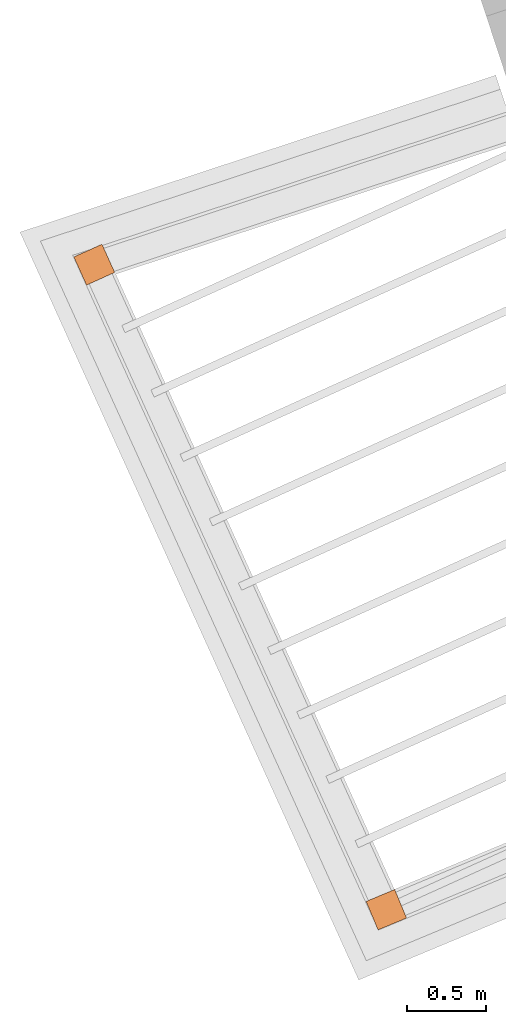
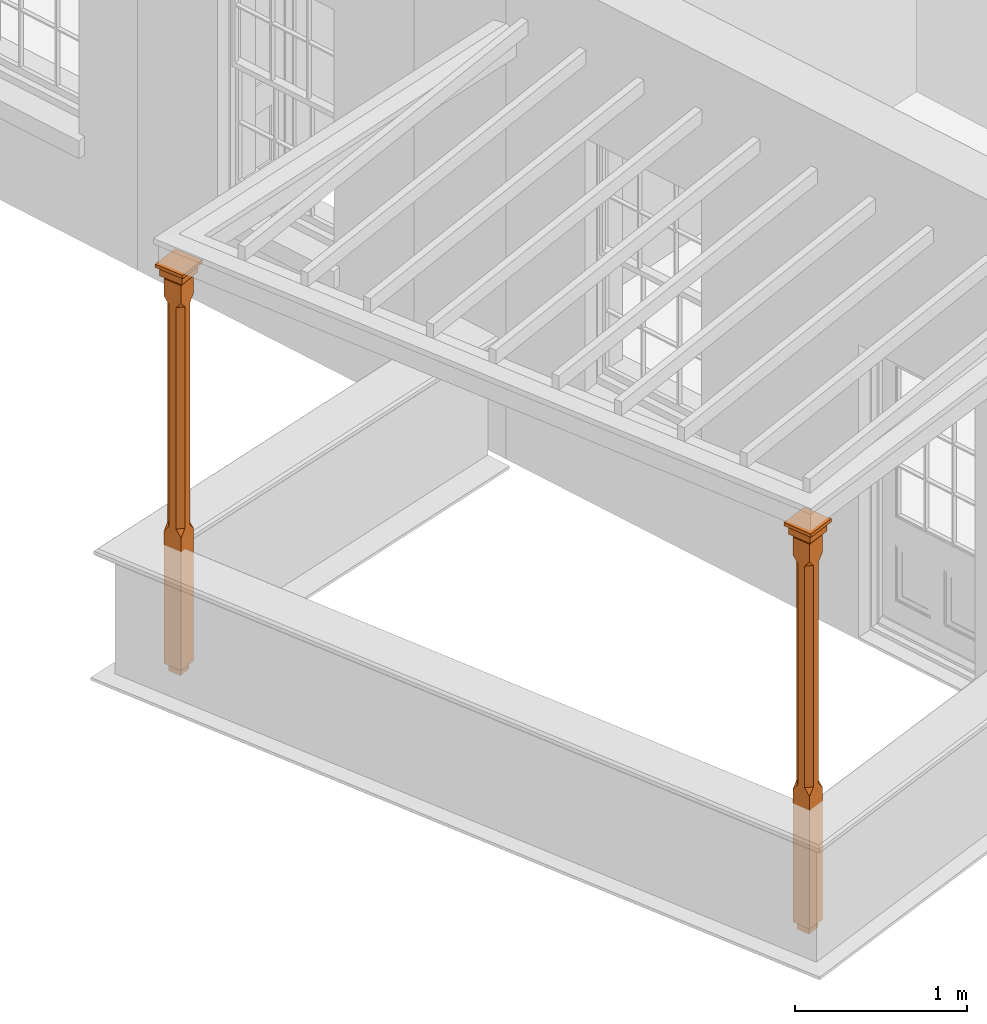
# One storey, part 10 of 10: 2 proxies.
"""IFC2X3 building model written with IfcOpenShell, lengths in metres."""

import ifcopenshell
import ifcopenshell.guid

model = None  # the IFC model being written
_history = None  # IfcOwnerHistory: only IFC2X3 demands one
_inside = {}  # id of a spatial element -> (the spatial element, [elements in it])
_under = {}  # id of a project, library or spatial element -> (it, [spatial elements below it])
_declared = {}  # id of a project -> (the project, [libraries it declares])
_typed = {}  # id of a type object -> (the type object, [elements of that type])
_made_of = {}  # id of a material, layer set ... -> (it, [elements and type objects made of it])


def new_model(schema):
    """Start an empty IFC model of exactly this schema.

    Asked for "IFC4X3", IfcOpenShell would pick the latest addendum, in which some entities
    have other attributes; the version numbers below select the first issue.
    IFC2X3 requires an IfcOwnerHistory on every rooted entity: one is made here for all.
    """
    global model, _history
    if schema == "IFC4X3":
        model = ifcopenshell.file(schema_version=(4, 3, 0, 0))
    else:
        model = ifcopenshell.file(schema=schema)
    _inside.clear()
    _under.clear()
    _declared.clear()
    _typed.clear()
    _made_of.clear()
    _history = None
    if model.schema == "IFC2X3":
        org = make("IfcOrganization", Name="unknown")
        user = make(
            "IfcPersonAndOrganization",
            ThePerson=make("IfcPerson", FamilyName="unknown"),
            TheOrganization=org,
        )
        app = make(
            "IfcApplication",
            ApplicationDeveloper=org,
            Version="unknown",
            ApplicationFullName="unknown",
            ApplicationIdentifier="unknown",
        )
        _history = make(
            "IfcOwnerHistory",
            OwningUser=user,
            OwningApplication=app,
            ChangeAction="ADDED",
            CreationDate=0,
        )
    return model


def make(cls, **values):
    """One entity of the class cls with the attributes given. An attribute that is None is left unset."""
    return model.create_entity(
        cls, **{name: value for name, value in values.items() if value is not None}
    )


def rooted(cls, **values):
    """An entity with a GlobalId (a new one), such as an element, a storey or a relation."""
    return make(cls, GlobalId=ifcopenshell.guid.new(), OwnerHistory=_history, **values)


def si_unit(unit_type, name, prefix=None):
    """IfcSIUnit, for example si_unit("LENGTHUNIT", "METRE", prefix="MILLI")."""
    return make("IfcSIUnit", UnitType=unit_type, Prefix=prefix, Name=name)


def assignment(units):
    """IfcUnitAssignment: the units of a project."""
    return None if units is None else make("IfcUnitAssignment", Units=units)


def point(xyz):
    """IfcCartesianPoint."""
    return None if xyz is None else make("IfcCartesianPoint", Coordinates=xyz)


def direction(xyz):
    """IfcDirection."""
    return None if xyz is None else make("IfcDirection", DirectionRatios=xyz)


def frame(location, z_axis=None, x_axis=None):
    """IfcAxis2Placement3D, a coordinate frame: its origin and axes. An axis left out is left unset."""
    return make(
        "IfcAxis2Placement3D",
        Location=point(location),
        Axis=direction(z_axis),
        RefDirection=direction(x_axis),
    )


def origin():
    """The frame at (0, 0, 0) with its axes left unset."""
    return frame((0.0, 0.0, 0.0))


def place(relative_to, where):
    """IfcLocalPlacement: puts the frame where relative to a parent placement (None: the world)."""
    return make(
        "IfcLocalPlacement", PlacementRelTo=relative_to, RelativePlacement=where
    )


def context(
    kind, dimensions, precision=None, world=None, true_north=None, identifier=None
):
    """IfcGeometricRepresentationContext, for example the 3D "Model" context."""
    return make(
        "IfcGeometricRepresentationContext",
        ContextIdentifier=identifier,
        ContextType=kind,
        CoordinateSpaceDimension=dimensions,
        Precision=precision,
        WorldCoordinateSystem=world,
        TrueNorth=true_north,
    )


def subcontext(parent, identifier, kind, view, scale=None):
    """IfcGeometricRepresentationSubContext, for example "Body" below "Model"."""
    return make(
        "IfcGeometricRepresentationSubContext",
        ContextIdentifier=identifier,
        ContextType=kind,
        ParentContext=parent,
        TargetScale=scale,
        TargetView=view,
    )


def project(units=None, contexts=None):
    """IfcProject with its units and contexts."""
    return rooted(
        "IfcProject",
        Name="project",
        RepresentationContexts=contexts,
        UnitsInContext=assignment(units),
    )


def spatial(cls, under=None, at=None, **own):
    """A site, building, storey or space (cls), placed at a placement, below another one or the project."""
    s = rooted(cls, ObjectPlacement=at, **own)
    if under is not None:
        _under.setdefault(under.id(), (under, []))[1].append(s)
    return s


def faces_of(points, faces, orient=None, outer=None):
    """IfcFace entities. A face is a list of loops; a loop is a list of indices into points, from 0.

    orient and outer hold one flag for each loop. By default every Orientation is true, the
    first loop of a face is its IfcFaceOuterBound and the others are IfcFaceBound.
    """
    made = []
    for i, loops in enumerate(faces):
        bounds = []
        for j, loop in enumerate(loops):
            is_outer = j == 0 if outer is None else outer[i][j]
            bounds.append(
                make(
                    "IfcFaceOuterBound" if is_outer else "IfcFaceBound",
                    Bound=make("IfcPolyLoop", Polygon=[points[k] for k in loop]),
                    Orientation=True if orient is None else orient[i][j],
                )
            )
        made.append(make("IfcFace", Bounds=bounds))
    return made


def faceted_brep(points, faces, orient=None, outer=None, voids=None):
    """IfcFacetedBrep: a solid bounded by flat faces; with voids (closed shells), ...WithVoids."""
    shared = [point(p) for p in points]
    hull = make("IfcClosedShell", CfsFaces=faces_of(shared, faces, orient, outer))
    if voids is None:
        return make("IfcFacetedBrep", Outer=hull)
    return make(
        "IfcFacetedBrepWithVoids",
        Outer=hull,
        Voids=[
            make(cls, CfsFaces=faces_of(shared, fs, o, b)) for cls, fs, o, b in voids
        ],
    )


def shape(context_of_items, identifier, shape_type, items):
    """IfcShapeRepresentation: the items that make up one representation, for example the "Body"."""
    return make(
        "IfcShapeRepresentation",
        ContextOfItems=context_of_items,
        RepresentationIdentifier=identifier,
        RepresentationType=shape_type,
        Items=items,
    )


def made_of(thing, what):
    """Note that an element or type object is made of a material, layer set ...; save() writes the relation."""
    if what is not None:
        _made_of.setdefault(what.id(), (what, []))[1].append(thing)
    return thing


def element(
    cls,
    number,
    at=None,
    inside=None,
    cuts=None,
    type_object=None,
    material=None,
    context=None,
    identifier="Body",
    shape_type=None,
    held_by="IfcProductDefinitionShape",
    body=None,
    shapes=None,
    **own,
):
    """One element of the class cls, such as IfcWall. Its Tag is "e" and its number.

    at: its placement. inside: the storey or other place that contains it. cuts: it is an
    opening in that element (IfcRelVoidsElement). A single representation is given by context,
    identifier, shape_type and body (its items); several are given by shapes. held_by: the class
    of the entity that holds the representations. save() writes the other relations.
    """
    e = rooted(cls, Tag="e%d" % number, ObjectPlacement=at, **own)
    if body is not None:
        shapes = [shape(context, identifier, shape_type, body)]
    if shapes is not None:
        e.Representation = make(held_by, Representations=shapes)
    if inside is not None:
        _inside.setdefault(inside.id(), (inside, []))[1].append(e)
    if cuts is not None:
        rooted(
            "IfcRelVoidsElement", RelatingBuildingElement=cuts, RelatedOpeningElement=e
        )
    if type_object is not None:
        _typed.setdefault(type_object.id(), (type_object, []))[1].append(e)
    return made_of(e, material)


def aggregate(whole, parts):
    """IfcRelAggregates: a whole, such as a stair, and the parts it consists of."""
    return rooted("IfcRelAggregates", RelatingObject=whole, RelatedObjects=parts)


def save(model, path):
    """Write the relations noted so far, then the file.

    IfcRelAggregates (storeys below a building ...), IfcRelContainedInSpatialStructure (elements
    in a storey), IfcRelDefinesByType, IfcRelAssociatesMaterial and IfcRelDeclares: one each for
    every whole, place, type object, material and project.
    """
    for whole, parts in _under.values():
        aggregate(whole, parts)
    for where, things in _inside.values():
        rooted(
            "IfcRelContainedInSpatialStructure",
            RelatedElements=things,
            RelatingStructure=where,
        )
    for kind, things in _typed.values():
        rooted("IfcRelDefinesByType", RelatedObjects=things, RelatingType=kind)
    for what, things in _made_of.values():
        rooted("IfcRelAssociatesMaterial", RelatedObjects=things, RelatingMaterial=what)
    for by, libraries in _declared.values():
        rooted("IfcRelDeclares", RelatingContext=by, RelatedDefinitions=libraries)
    model.write(path)


model = new_model("IFC2X3")

# Units and contexts
model_context = context("Model", 3, world=origin())
body_context = subcontext(model_context, "Body", "Model", "MODEL_VIEW")
ifc_project = project(units=[si_unit("PLANEANGLEUNIT", "RADIAN"), si_unit("MASSUNIT", "GRAM", prefix="KILO"), si_unit("FORCEUNIT", "NEWTON", prefix="KILO"), si_unit("LENGTHUNIT", "METRE")], contexts=[model_context])

# Site, building, storey
site_placement = place(None, origin())
site = spatial("IfcSite", under=ifc_project, at=site_placement, CompositionType="ELEMENT")
building_placement = place(None, origin())
building = spatial("IfcBuilding", under=site, at=building_placement, Name="Building plot-2", CompositionType="ELEMENT")
storey_placement = place(None, frame((0.0, 0.0, 4.6)))
storey = spatial("IfcBuildingStorey", under=building, at=storey_placement, Name="Floor 1", CompositionType="ELEMENT", Elevation=4.6)

# Proxies
proxy_1_placement = place(storey_placement, frame((26.6320151404297, 29.6644036171361, 0.0), z_axis=(0.0, 0.0, 1.0), x_axis=(0.412540918322107, -0.910939070799992, 0.0)))
element("IfcBuildingElementProxy", 1, at=proxy_1_placement, inside=storey, Name="pergola post", CompositionType="ELEMENT", context=body_context, shape_type="Brep", held_by="IfcProductRepresentation", body=[
    faceted_brep([(0.0246, -0.0615, 2.62), (0.0615, -0.0246, 2.62), (0.0615, -0.0615, 2.666667), (0.0615, -0.0246, 1.044444), (0.0246, -0.0615, 1.044444), (0.0615, 0.0246, 2.62), (0.0615, 0.0615, 2.666667), (-0.0246, -0.0615, 2.62), (-0.0615, -0.0615, 2.666667), (-0.0246, -0.0615, 1.044444), (0.0615, -0.0615, 0.997778), (0.0615, 0.0246, 1.044444), (0.0246, 0.0615, 2.62), (0.0615, 0.0615, 2.791111), (0.0615, -0.0615, 2.791111), (-0.0615, -0.0615, 2.791111), (-0.0615, -0.0246, 2.62), (-0.0615, -0.0246, 1.044444), (-0.0615, -0.0615, 0.997778), (0.0615, 0.0615, 0.997778), (0.0246, 0.0615, 1.044444), (-0.0246, 0.0615, 2.62), (-0.0615, 0.0615, 2.666667), (0.04305, 0.04305, 2.791111), (0.04305, -0.04305, 2.791111), (-0.0615, 0.0615, 2.791111), (-0.04305, -0.04305, 2.791111), (-0.0615, 0.0246, 2.62), (-0.0615, 0.0246, 1.044444), (0.0615, -0.0615, 0.053333), (-0.0615, -0.0615, 0.053333), (0.0615, 0.0615, 0.053333), (-0.0246, 0.0615, 1.044444), (-0.04305, 0.04305, 2.791111), (0.04305, 0.04305, 2.814444), (0.04305, -0.04305, 2.814444), (-0.04305, -0.04305, 2.814444), (-0.0615, 0.0615, 0.997778), (-0.0615, 0.0615, 0.053333), (-0.04305, -0.04305, 0.053333), (0.04305, -0.04305, 0.053333), (0.04305, 0.04305, 0.053333), (-0.04305, 0.04305, 2.814444), (0.07995, 0.07995, 2.814444), (0.07995, -0.07995, 2.814444), (-0.07995, -0.07995, 2.814444), (-0.04305, 0.04305, 0.053333), (-0.04305, -0.04305, 0.0), (0.04305, -0.04305, 0.0), (0.04305, 0.04305, 0.0), (-0.07995, 0.07995, 2.814444), (0.07995, 0.07995, 2.876667), (0.07995, -0.07995, 2.876667), (-0.07995, -0.07995, 2.876667), (-0.04305, 0.04305, 0.0), (-0.07995, 0.07995, 2.876667), (0.0984, 0.0984, 2.876667), (0.0984, -0.0984, 2.876667), (-0.0984, -0.0984, 2.876667), (-0.0984, 0.0984, 2.876667), (0.0984, 0.0984, 2.9), (0.0984, -0.0984, 2.9), (-0.0984, -0.0984, 2.9), (-0.0984, 0.0984, 2.9)], [[[0, 1, 2]], [[3, 1, 0, 4]], [[1, 5, 6, 2]], [[7, 0, 2, 8]], [[4, 0, 7, 9]], [[3, 4, 10]], [[1, 3, 11, 5]], [[5, 12, 6]], [[13, 14, 2, 6]], [[15, 8, 2, 14]], [[8, 16, 7]], [[9, 7, 16, 17]], [[9, 18, 10, 4]], [[3, 10, 19, 11]], [[20, 12, 5, 11]], [[21, 22, 6, 12]], [[14, 13, 23, 24]], [[13, 6, 22, 25]], [[25, 22, 8, 15]], [[26, 15, 14, 24]], [[16, 8, 22, 27]], [[27, 28, 17, 16]], [[17, 18, 9]], [[29, 10, 18, 30]], [[31, 19, 10, 29]], [[20, 11, 19]], [[12, 20, 32, 21]], [[21, 27, 22]], [[33, 23, 13, 25]], [[23, 34, 35, 24]], [[26, 33, 25, 15]], [[36, 26, 24, 35]], [[28, 27, 21, 32]], [[17, 28, 37, 18]], [[38, 30, 18, 37]], [[29, 30, 39, 40]], [[31, 38, 37, 19]], [[40, 41, 31, 29]], [[32, 20, 19, 37]], [[33, 42, 34, 23]], [[43, 44, 35, 34]], [[42, 33, 26, 36]], [[36, 35, 44, 45]], [[28, 32, 37]], [[46, 39, 30, 38]], [[39, 47, 48, 40]], [[46, 38, 31, 41]], [[49, 41, 40, 48]], [[43, 34, 42, 50]], [[43, 51, 52, 44]], [[45, 50, 42, 36]], [[53, 45, 44, 52]], [[46, 54, 47, 39]], [[54, 46, 41, 49]], [[50, 55, 51, 43]], [[56, 57, 52, 51]], [[55, 50, 45, 53]], [[53, 52, 57, 58]], [[56, 51, 55, 59]], [[56, 60, 61, 57]], [[58, 59, 55, 53]], [[62, 58, 57, 61]], [[59, 63, 60, 56]], [[63, 62, 61, 60]], [[58, 62, 63, 59]], [[47, 54, 49, 48]]]),
])
proxy_2_placement = place(storey_placement, frame((28.4917456581951, 25.557898990439, 0.0), z_axis=(0.0, 0.0, 1.0), x_axis=(0.922882566139946, 0.38508150970275, 0.0)))
element("IfcBuildingElementProxy", 2, at=proxy_2_placement, inside=storey, Name="pergola post", CompositionType="ELEMENT", context=body_context, shape_type="Brep", held_by="IfcProductRepresentation", body=[
    faceted_brep([(0.0246, -0.0615, 2.62), (0.0615, -0.0246, 2.62), (0.0615, -0.0615, 2.666667), (0.0615, -0.0246, 1.044444), (0.0246, -0.0615, 1.044444), (0.0615, 0.0246, 2.62), (0.0615, 0.0615, 2.666667), (-0.0246, -0.0615, 2.62), (-0.0615, -0.0615, 2.666667), (-0.0246, -0.0615, 1.044444), (0.0615, -0.0615, 0.997778), (0.0615, 0.0246, 1.044444), (0.0246, 0.0615, 2.62), (0.0615, 0.0615, 2.791111), (0.0615, -0.0615, 2.791111), (-0.0615, -0.0615, 2.791111), (-0.0615, -0.0246, 2.62), (-0.0615, -0.0246, 1.044444), (-0.0615, -0.0615, 0.997778), (0.0615, 0.0615, 0.997778), (0.0246, 0.0615, 1.044444), (-0.0246, 0.0615, 2.62), (-0.0615, 0.0615, 2.666667), (0.04305, 0.04305, 2.791111), (0.04305, -0.04305, 2.791111), (-0.0615, 0.0615, 2.791111), (-0.04305, -0.04305, 2.791111), (-0.0615, 0.0246, 2.62), (-0.0615, 0.0246, 1.044444), (0.0615, -0.0615, 0.053333), (-0.0615, -0.0615, 0.053333), (0.0615, 0.0615, 0.053333), (-0.0246, 0.0615, 1.044444), (-0.04305, 0.04305, 2.791111), (0.04305, 0.04305, 2.814444), (0.04305, -0.04305, 2.814444), (-0.04305, -0.04305, 2.814444), (-0.0615, 0.0615, 0.997778), (-0.0615, 0.0615, 0.053333), (-0.04305, -0.04305, 0.053333), (0.04305, -0.04305, 0.053333), (0.04305, 0.04305, 0.053333), (-0.04305, 0.04305, 2.814444), (0.07995, 0.07995, 2.814444), (0.07995, -0.07995, 2.814444), (-0.07995, -0.07995, 2.814444), (-0.04305, 0.04305, 0.053333), (-0.04305, -0.04305, 0.0), (0.04305, -0.04305, 0.0), (0.04305, 0.04305, 0.0), (-0.07995, 0.07995, 2.814444), (0.07995, 0.07995, 2.876667), (0.07995, -0.07995, 2.876667), (-0.07995, -0.07995, 2.876667), (-0.04305, 0.04305, 0.0), (-0.07995, 0.07995, 2.876667), (0.0984, 0.0984, 2.876667), (0.0984, -0.0984, 2.876667), (-0.0984, -0.0984, 2.876667), (-0.0984, 0.0984, 2.876667), (0.0984, 0.0984, 2.9), (0.0984, -0.0984, 2.9), (-0.0984, -0.0984, 2.9), (-0.0984, 0.0984, 2.9)], [[[0, 1, 2]], [[3, 1, 0, 4]], [[1, 5, 6, 2]], [[7, 0, 2, 8]], [[4, 0, 7, 9]], [[3, 4, 10]], [[1, 3, 11, 5]], [[5, 12, 6]], [[13, 14, 2, 6]], [[15, 8, 2, 14]], [[8, 16, 7]], [[9, 7, 16, 17]], [[9, 18, 10, 4]], [[3, 10, 19, 11]], [[20, 12, 5, 11]], [[21, 22, 6, 12]], [[14, 13, 23, 24]], [[13, 6, 22, 25]], [[25, 22, 8, 15]], [[26, 15, 14, 24]], [[16, 8, 22, 27]], [[27, 28, 17, 16]], [[17, 18, 9]], [[29, 10, 18, 30]], [[31, 19, 10, 29]], [[20, 11, 19]], [[12, 20, 32, 21]], [[21, 27, 22]], [[33, 23, 13, 25]], [[23, 34, 35, 24]], [[26, 33, 25, 15]], [[36, 26, 24, 35]], [[28, 27, 21, 32]], [[17, 28, 37, 18]], [[38, 30, 18, 37]], [[29, 30, 39, 40]], [[31, 38, 37, 19]], [[40, 41, 31, 29]], [[32, 20, 19, 37]], [[33, 42, 34, 23]], [[43, 44, 35, 34]], [[42, 33, 26, 36]], [[36, 35, 44, 45]], [[28, 32, 37]], [[46, 39, 30, 38]], [[39, 47, 48, 40]], [[46, 38, 31, 41]], [[49, 41, 40, 48]], [[43, 34, 42, 50]], [[43, 51, 52, 44]], [[45, 50, 42, 36]], [[53, 45, 44, 52]], [[46, 54, 47, 39]], [[54, 46, 41, 49]], [[50, 55, 51, 43]], [[56, 57, 52, 51]], [[55, 50, 45, 53]], [[53, 52, 57, 58]], [[56, 51, 55, 59]], [[56, 60, 61, 57]], [[58, 59, 55, 53]], [[62, 58, 57, 61]], [[59, 63, 60, 56]], [[63, 62, 61, 60]], [[58, 62, 63, 59]], [[47, 54, 49, 48]]]),
])

save(model, "model.ifc")
